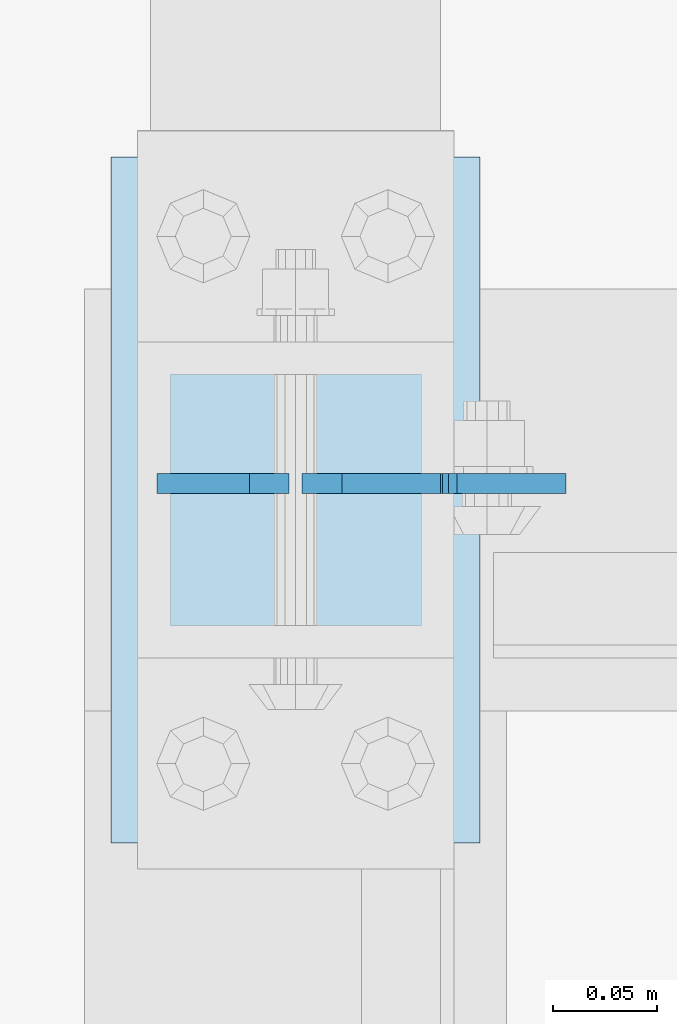
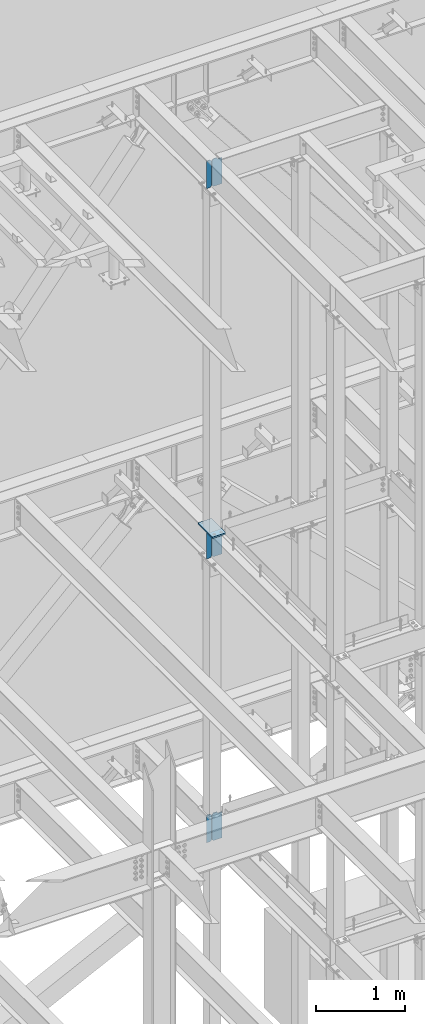
# One storey, part 1082 of 1179: 7 plates, 4 elements without a shape of their own.
"""IFC2X3 building model written with IfcOpenShell, lengths in millimetres."""

from ifc_helpers import new_model, si_unit, frame, origin_with_axes, place, context, subcontext, project, spatial, faceted_brep, material, type_object, element, aggregate, save


model = new_model("IFC2X3")

# Units and contexts
model_context = context("Model", 3, precision=1e-05, world=origin_with_axes())
body_context = subcontext(model_context, "Body", "Model", "MODEL_VIEW")
ifc_project = project(units=[si_unit("LENGTHUNIT", "METRE", prefix="MILLI"), si_unit("AREAUNIT", "SQUARE_METRE"), si_unit("VOLUMEUNIT", "CUBIC_METRE"), si_unit("MASSUNIT", "GRAM", prefix="KILO"), si_unit("TIMEUNIT", "SECOND"), si_unit("PLANEANGLEUNIT", "RADIAN"), si_unit("SOLIDANGLEUNIT", "STERADIAN"), si_unit("THERMODYNAMICTEMPERATUREUNIT", "DEGREE_CELSIUS"), si_unit("LUMINOUSINTENSITYUNIT", "LUMEN")], contexts=[model_context])

# Site, building, storey
site_placement = place(None, origin_with_axes())
site = spatial("IfcSite", under=ifc_project, at=site_placement, CompositionType="ELEMENT")
building_placement = place(site_placement, origin_with_axes())
building = spatial("IfcBuilding", under=site, at=building_placement, Name="Undefined", CompositionType="ELEMENT")
storey_placement = place(building_placement, origin_with_axes())
storey = spatial("IfcBuildingStorey", under=building, at=storey_placement, Name="Undefined", CompositionType="ELEMENT", Elevation=0.0)

# Assembly, plate
assembly_1_placement = place(storey_placement, origin_with_axes())
assembly_1 = element("IfcElementAssembly", 1, at=assembly_1_placement, inside=storey, Name="BEAM", AssemblyPlace="NOTDEFINED", PredefinedType="RIGID_FRAME")
ifc_material = material(Name="STEEL/A36")
plate_type_1 = type_object("IfcPlateType", PredefinedType="NOTDEFINED")
plate_1_placement = place(assembly_1_placement, frame((11877.675, 39441.4379999161, 7623.175), z_axis=(0.0, 0.0, 1.0), x_axis=(1.0, 0.0, 0.0)))
plate_1 = element("IfcPlate", 2, at=plate_1_placement, type_object=plate_type_1, material=ifc_material, Name="PLATE", context=body_context, shape_type="Brep", body=[
    faceted_brep([(66.6749998164378, -4.76249999999709, 377.825), (66.6749999434469, -4.76249999999709, 371.474999553748), (66.6749999434469, 4.76249999999709, 371.474999553748), (66.6749998164378, 4.76249999999709, 377.825), (67.641729938794, -4.76249999999709, 366.614920114053), (67.641729938794, 4.76249999999709, 366.614920114053), (70.394743855788, -4.76249999999709, 362.494743732281), (70.394743855788, 4.76249999999709, 362.494743732281), (74.5149202922948, -4.76249999999709, 359.741729897201), (74.5149202922948, 4.76249999999709, 359.741729897201), (79.3749997512095, -4.76249999999709, 358.774999998475), (79.3749997512095, 4.76249999999709, 358.774999998475), (127.000000004868, -4.76249999999709, 358.774999992755), (127.0, 4.76249999999709, 358.774999992755), (0.0, -4.76249999999709, 358.775000762939), (19.0499992370605, -4.76249999999709, 377.825), (19.0499992370605, 4.76249999999709, 377.825), (0.0, 4.76249999999709, 358.775000762939), (0.0, -4.76250000000073, 19.0499992370605), (0.0, 4.76250000000073, 19.0499992370605), (19.0499992370605, -4.76250000000073, 0.0), (19.0499992370605, 4.76250000000073, 0.0), (127.0, -4.76250000000073, 0.0), (127.0, 4.76250000000073, 0.0)], [[[0, 1, 2, 3]], [[4, 5, 2, 1]], [[6, 7, 5, 4]], [[8, 9, 7, 6]], [[10, 11, 9, 8]], [[12, 13, 11, 10]], [[14, 15, 16, 17]], [[18, 14, 17, 19]], [[20, 18, 19, 21]], [[22, 20, 21, 23]], [[8, 6, 4, 1, 0, 15, 14, 18, 20, 22, 12, 10]], [[16, 15, 0, 3]], [[23, 21, 19, 17, 16, 3, 2, 5, 7, 9, 11, 13]], [[22, 23, 13, 12]]]),
])

assembly_2_placement = place(storey_placement, origin_with_axes())
assembly_2 = element("IfcElementAssembly", 3, at=assembly_2_placement, inside=storey, Name="BEAM", AssemblyPlace="NOTDEFINED", PredefinedType="RIGID_FRAME")
plate_2_placement = place(assembly_2_placement, frame((11877.6750424827, 39441.4379707852, 3711.575), z_axis=(0.0, 0.0, 1.0), x_axis=(1.0, 0.0, 0.0)))
plate_2 = element("IfcPlate", 4, at=plate_2_placement, type_object=plate_type_1, material=ifc_material, Name="PLATE", context=body_context, shape_type="Brep", body=[
    faceted_brep([(66.6756118831599, -4.76249999999709, 377.825), (66.6754110961774, -4.76249999999709, 371.475401414235), (66.6754122391831, 4.76249999999709, 371.4754014142), (66.675613026182, 4.76249999999709, 377.825), (67.6420257521768, -4.76249999999709, 366.615198568966), (67.6420268951824, 4.76249999999709, 366.615198568931), (70.3950129291698, -4.76249999999709, 362.494885814615), (70.3950140721736, 4.76249999999709, 362.49488581458), (74.5152386277114, -4.76249999999709, 359.741768348284), (74.515239770717, 4.76249999999709, 359.741768348249), (79.3754109046859, -4.76249999999709, 358.775000005575), (79.3754120476915, 4.76249999999709, 358.775000005541), (127.000000004868, -4.76249999999709, 358.774999992755), (127.0, 4.76249999999709, 358.774999992755), (0.0, -4.76249999999709, 358.775000762939), (19.0499992370605, -4.76249999999709, 377.825), (19.0499992370605, 4.76249999999709, 377.825), (0.0, 4.76249999999709, 358.775000762939), (0.0, -4.76250000000073, 19.0499992370605), (0.0, 4.76250000000073, 19.0499992370605), (19.0499992370605, -4.76250000000073, 0.0), (19.0499992370605, 4.76250000000073, 0.0), (127.0, -4.76250000000073, 0.0), (127.0, 4.76250000000073, 0.0)], [[[0, 1, 2, 3]], [[4, 5, 2, 1]], [[6, 7, 5, 4]], [[8, 9, 7, 6]], [[10, 11, 9, 8]], [[12, 13, 11, 10]], [[14, 15, 16, 17]], [[18, 14, 17, 19]], [[20, 18, 19, 21]], [[22, 20, 21, 23]], [[8, 6, 4, 1, 0, 15, 14, 18, 20, 22, 12, 10]], [[16, 15, 0, 3]], [[23, 21, 19, 17, 16, 3, 2, 5, 7, 9, 11, 13]], [[22, 23, 13, 12]]]),
])

assembly_3_placement = place(storey_placement, origin_with_axes())
assembly_3 = element("IfcElementAssembly", 5, at=assembly_3_placement, inside=storey, Name="BEAM", AssemblyPlace="NOTDEFINED", PredefinedType="RIGID_FRAME")
plate_3_placement = place(assembly_3_placement, frame((11877.675, 39441.4379999161, 12728.575), z_axis=(0.0, 0.0, 1.0), x_axis=(1.0, 0.0, 0.0)))
plate_3 = element("IfcPlate", 6, at=plate_3_placement, type_object=plate_type_1, material=ifc_material, Name="PLATE", context=body_context, shape_type="Brep", body=[
    faceted_brep([(66.6749998164378, -4.76249999999709, 377.825), (66.6749999434469, -4.76249999999709, 371.474999553748), (66.6749999434469, 4.76249999999709, 371.474999553748), (66.6749998164378, 4.76249999999709, 377.825), (67.641729938794, -4.76249999999709, 366.614920114053), (67.641729938794, 4.76249999999709, 366.614920114053), (70.394743855788, -4.76249999999709, 362.494743732281), (70.394743855788, 4.76249999999709, 362.494743732281), (74.5149202922948, -4.76249999999709, 359.741729897201), (74.5149202922948, 4.76249999999709, 359.741729897201), (79.3749997512095, -4.76249999999709, 358.774999998475), (79.3749997512095, 4.76249999999709, 358.774999998475), (127.000000004868, -4.76249999999709, 358.774999992755), (127.0, 4.76249999999709, 358.774999992755), (0.0, -4.76249999999709, 358.775000762939), (19.0499992370605, -4.76249999999709, 377.825), (19.0499992370605, 4.76249999999709, 377.825), (0.0, 4.76249999999709, 358.775000762939), (0.0, -4.76250000000073, 19.0499992370605), (0.0, 4.76250000000073, 19.0499992370605), (19.0499992370605, -4.76250000000073, 0.0), (19.0499992370605, 4.76250000000073, 0.0), (127.0, -4.76250000000073, 0.0), (127.0, 4.76250000000073, 0.0)], [[[0, 1, 2, 3]], [[4, 5, 2, 1]], [[6, 7, 5, 4]], [[8, 9, 7, 6]], [[10, 11, 9, 8]], [[12, 13, 11, 10]], [[14, 15, 16, 17]], [[18, 14, 17, 19]], [[20, 18, 19, 21]], [[22, 20, 21, 23]], [[8, 6, 4, 1, 0, 15, 14, 18, 20, 22, 12, 10]], [[16, 15, 0, 3]], [[23, 21, 19, 17, 16, 3, 2, 5, 7, 9, 11, 13]], [[22, 23, 13, 12]]]),
])

assembly_4_placement = place(storey_placement, origin_with_axes())
assembly_4 = element("IfcElementAssembly", 7, at=assembly_4_placement, inside=storey, Name="COLUMN", AssemblyPlace="NOTDEFINED", PredefinedType="RIGID_FRAME")
plate_type_2 = type_object("IfcPlateType", PredefinedType="NOTDEFINED")
plate_4_placement = place(assembly_4_placement, frame((11785.6, 39268.4, 8023.225), z_axis=(0.0, 1.0, 0.0), x_axis=(1.0, 0.0, 0.0)))
plate_4 = element("IfcPlate", 8, at=plate_4_placement, type_object=plate_type_2, material=ifc_material, Name="PLATE", context=body_context, shape_type="Brep", body=[
    faceted_brep([(0.0, -9.52499999999964, 0.0), (0.0, -9.52499999999964, 330.200012207031), (0.0, 9.52499999999964, 330.200012207031), (0.0, 9.52499999999964, 0.0), (177.800003051758, -9.52499999999964, 330.200012207031), (177.800003051758, 9.52499999999964, 330.200012207031), (177.800003051758, -9.52499999999964, 0.0), (177.800003051758, 9.52499999999964, 0.0)], [[[0, 1, 2, 3]], [[1, 4, 5, 2]], [[4, 6, 7, 5]], [[6, 0, 3, 7]], [[5, 7, 3, 2]], [[6, 4, 1, 0]]]),
])
aggregate(assembly_4, [plate_4])

# Plate
plate_type_3 = type_object("IfcPlateType", PredefinedType="NOTDEFINED")
plate_5_placement = place(assembly_1_placement, frame((11871.325, 39441.4379999161, 7623.175), z_axis=(0.0, 0.0, 1.0), x_axis=(-1.0, 0.0, 0.0)))
plate_5 = element("IfcPlate", 9, at=plate_5_placement, type_object=plate_type_3, material=ifc_material, Name="PLATE", context=body_context, shape_type="Brep", body=[
    faceted_brep([(0.0, -4.76250000000073, 19.0499992370605), (0.0, -4.76249999999709, 358.775000762939), (0.0, 4.76249999999709, 358.775000762939), (0.0, 4.76250000000073, 19.0499992370605), (19.0499992370605, -4.76249999999709, 377.825), (19.0499992370605, 4.76249999999709, 377.825), (63.5, -4.76250000000073, 377.825012207031), (63.5, 4.76250000000073, 377.825012207031), (63.5, -4.76250000000073, 0.0), (63.5, 4.76250000000073, 0.0), (19.0499992370605, -4.76250000000073, 0.0), (19.0499992370605, 4.76250000000073, 0.0)], [[[0, 1, 2, 3]], [[1, 4, 5, 2]], [[4, 6, 7, 5]], [[6, 8, 9, 7]], [[8, 10, 11, 9]], [[10, 0, 3, 11]], [[5, 7, 9, 11, 3, 2]], [[10, 8, 6, 4, 1, 0]]]),
])

aggregate(assembly_1, [plate_5, plate_1])

plate_6_placement = place(assembly_2_placement, frame((11871.3250423637, 39441.4379706264, 3711.575), z_axis=(0.0, 0.0, 1.0), x_axis=(-1.0, 0.0, 0.0)))
plate_6 = element("IfcPlate", 10, at=plate_6_placement, type_object=plate_type_3, material=ifc_material, Name="PLATE", context=body_context, shape_type="Brep", body=[
    faceted_brep([(0.0, -4.76250000000073, 19.0499992370605), (0.0, -4.76249999999709, 358.775000762939), (0.0, 4.76249999999709, 358.775000762939), (0.0, 4.76250000000073, 19.0499992370605), (19.0499992370605, -4.76249999999709, 377.825), (19.0499992370605, 4.76249999999709, 377.825), (63.5, -4.76250000000073, 377.825012207031), (63.5, 4.76250000000073, 377.825012207031), (63.5, -4.76250000000073, 0.0), (63.5, 4.76250000000073, 0.0), (19.0499992370605, -4.76250000000073, 0.0), (19.0499992370605, 4.76250000000073, 0.0)], [[[0, 1, 2, 3]], [[1, 4, 5, 2]], [[4, 6, 7, 5]], [[6, 8, 9, 7]], [[8, 10, 11, 9]], [[10, 0, 3, 11]], [[5, 7, 9, 11, 3, 2]], [[10, 8, 6, 4, 1, 0]]]),
])

aggregate(assembly_2, [plate_6, plate_2])

plate_7_placement = place(assembly_3_placement, frame((11871.325, 39441.4379999161, 12728.575), z_axis=(0.0, 0.0, 1.0), x_axis=(-1.0, 0.0, 0.0)))
plate_7 = element("IfcPlate", 11, at=plate_7_placement, type_object=plate_type_3, material=ifc_material, Name="PLATE", context=body_context, shape_type="Brep", body=[
    faceted_brep([(0.0, -4.76250000000073, 19.0499992370605), (0.0, -4.76249999999709, 358.775000762939), (0.0, 4.76249999999709, 358.775000762939), (0.0, 4.76250000000073, 19.0499992370605), (19.0499992370605, -4.76249999999709, 377.825), (19.0499992370605, 4.76249999999709, 377.825), (63.5, -4.76250000000073, 377.825012207031), (63.5, 4.76250000000073, 377.825012207031), (63.5, -4.76250000000073, 0.0), (63.5, 4.76250000000073, 0.0), (19.0499992370605, -4.76250000000073, 0.0), (19.0499992370605, 4.76250000000073, 0.0)], [[[0, 1, 2, 3]], [[1, 4, 5, 2]], [[4, 6, 7, 5]], [[6, 8, 9, 7]], [[8, 10, 11, 9]], [[10, 0, 3, 11]], [[5, 7, 9, 11, 3, 2]], [[10, 8, 6, 4, 1, 0]]]),
])

aggregate(assembly_3, [plate_7, plate_3])

save(model, "model.ifc")
